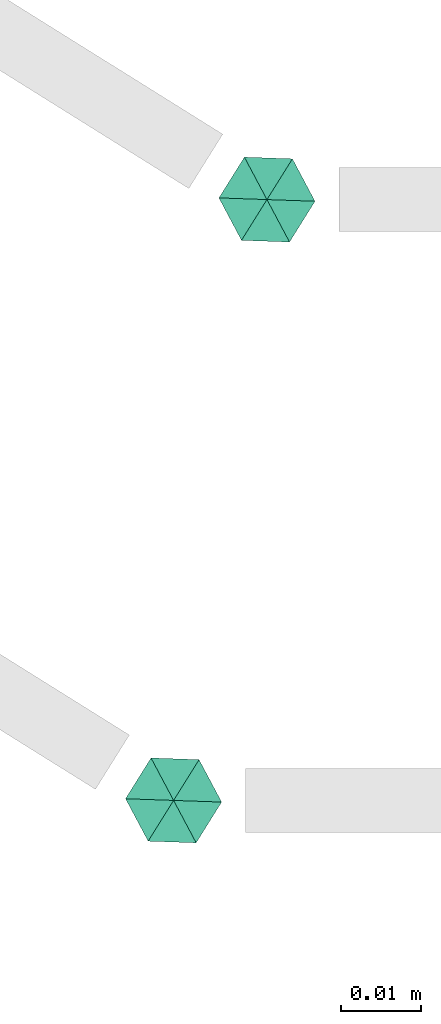
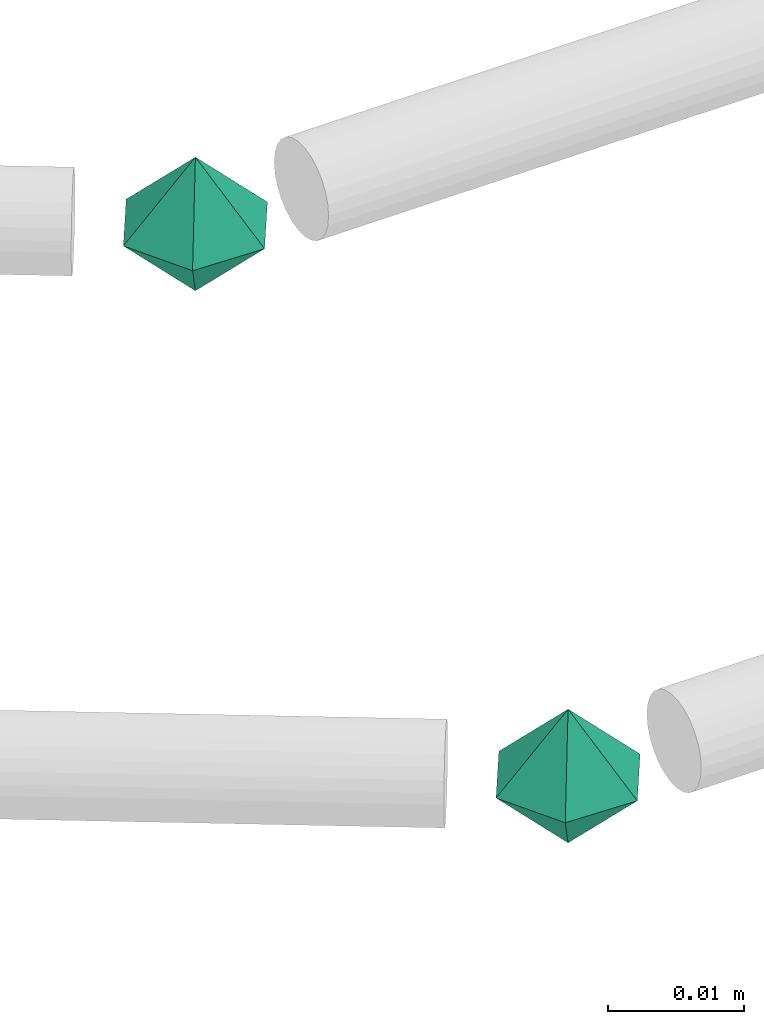
# One storey, part 50 of 65: 2 flow fittings.
"""IFC2X3 building model written with IfcOpenShell, lengths in millimetres."""

from ifc_helpers import new_model, entity, si_unit, converted_unit, derived_unit, direction, frame, origin, place, context, subcontext, project, spatial, faceted_brep, source, transform, mapped, material, material_list, type_object, type_shapes, element, save


model = new_model("IFC2X3")

# Units and contexts
model_context = context("Model", 3, precision=0.01, world=origin(), true_north=direction((6.12303176911189e-17, 1.0)))
body_context = subcontext(model_context, "Body", "Model", "MODEL_VIEW")
ifc_project = project(units=[si_unit("LENGTHUNIT", "METRE", prefix="MILLI"), si_unit("AREAUNIT", "SQUARE_METRE"), si_unit("VOLUMEUNIT", "CUBIC_METRE"), converted_unit("PLANEANGLEUNIT", "DEGREE", entity("IfcRatioMeasure", 0.0174532925199433), si_unit("PLANEANGLEUNIT", "RADIAN"), dimensions=[0, 0, 0, 0, 0, 0, 0]), si_unit("MASSUNIT", "GRAM", prefix="KILO"), derived_unit("MASSDENSITYUNIT", [(si_unit("MASSUNIT", "GRAM", prefix="KILO"), 1), (si_unit("LENGTHUNIT", "METRE"), -3)]), derived_unit("MOMENTOFINERTIAUNIT", [(si_unit("LENGTHUNIT", "METRE"), 4)]), si_unit("TIMEUNIT", "SECOND"), si_unit("FREQUENCYUNIT", "HERTZ"), si_unit("THERMODYNAMICTEMPERATUREUNIT", "DEGREE_CELSIUS"), derived_unit("THERMALTRANSMITTANCEUNIT", [(si_unit("MASSUNIT", "GRAM", prefix="KILO"), 1), (si_unit("THERMODYNAMICTEMPERATUREUNIT", "KELVIN"), -1), (si_unit("TIMEUNIT", "SECOND"), -3)]), derived_unit("VOLUMETRICFLOWRATEUNIT", [(si_unit("LENGTHUNIT", "METRE"), 3), (si_unit("TIMEUNIT", "SECOND"), -1)]), derived_unit("MASSFLOWRATEUNIT", [(si_unit("MASSUNIT", "GRAM", prefix="KILO"), 1), (si_unit("TIMEUNIT", "SECOND"), -1)]), derived_unit("ROTATIONALFREQUENCYUNIT", [(si_unit("TIMEUNIT", "SECOND"), -1)]), si_unit("ELECTRICCURRENTUNIT", "AMPERE"), si_unit("ELECTRICVOLTAGEUNIT", "VOLT"), si_unit("POWERUNIT", "WATT"), si_unit("FORCEUNIT", "NEWTON", prefix="KILO"), si_unit("ILLUMINANCEUNIT", "LUX"), si_unit("LUMINOUSFLUXUNIT", "LUMEN"), si_unit("LUMINOUSINTENSITYUNIT", "CANDELA"), derived_unit("USERDEFINED", [(si_unit("MASSUNIT", "GRAM", prefix="KILO"), -1), (si_unit("LENGTHUNIT", "METRE"), -2), (si_unit("TIMEUNIT", "SECOND"), 3), (si_unit("LUMINOUSFLUXUNIT", "LUMEN"), 1)]), derived_unit("LINEARVELOCITYUNIT", [(si_unit("LENGTHUNIT", "METRE"), 1), (si_unit("TIMEUNIT", "SECOND"), -1)]), si_unit("PRESSUREUNIT", "PASCAL"), derived_unit("USERDEFINED", [(si_unit("LENGTHUNIT", "METRE"), -2), (si_unit("MASSUNIT", "GRAM", prefix="KILO"), 1), (si_unit("TIMEUNIT", "SECOND"), -2)]), derived_unit("LINEARFORCEUNIT", [(si_unit("MASSUNIT", "GRAM", prefix="KILO"), 1), (si_unit("LENGTHUNIT", "METRE"), 1), (si_unit("TIMEUNIT", "SECOND"), -2), (si_unit("LENGTHUNIT", "METRE"), -1)]), derived_unit("PLANARFORCEUNIT", [(si_unit("MASSUNIT", "GRAM", prefix="KILO"), 1), (si_unit("LENGTHUNIT", "METRE"), 1), (si_unit("TIMEUNIT", "SECOND"), -2), (si_unit("LENGTHUNIT", "METRE"), -2)])], contexts=[model_context])

# Site, building, storey
site_placement = place(None, frame((0.0, -0.00077364408347762, 0.0)))
site = spatial("IfcSite", under=ifc_project, at=site_placement, CompositionType="ELEMENT")
building_placement = place(site_placement, origin())
building = spatial("IfcBuilding", under=site, at=building_placement, CompositionType="ELEMENT")
storey_placement = place(building_placement, frame((0.0, 0.0, 19800.0)))
storey = spatial("IfcBuildingStorey", under=building, at=storey_placement, CompositionType="ELEMENT", Elevation=19800.0)

# Flow fittings
ifc_material_1 = material()
ifc_material_2 = material()
ifc_material_list = material_list([ifc_material_2, ifc_material_1])
pipe_fitting_type = type_object("IfcPipeFittingType", PredefinedType="NOTDEFINED", material=ifc_material_list)
shared_shape = source(origin(), body_context, "Body", "Brep", [
    faceted_brep([(5.19615242271291, 3.0, 0.0), (1.81736279215797e-07, 1.95255435220254e-07, -6.0), (0.0, 6.0, 0.0), (5.19615242271289, -3.0, 0.0), (0.0, -6.0, 0.0), (-5.19615242270038, 3.0, 0.0), (-5.19615242270037, -3.0, 0.0), (-7.73803144365858e-08, 6.63990943561288e-08, 6.0)], [[[0, 1, 2]], [[1, 0, 3]], [[1, 3, 4]], [[5, 1, 6]], [[1, 4, 6]], [[2, 1, 5]], [[5, 7, 2]], [[7, 5, 6]], [[7, 6, 4]], [[0, 7, 3]], [[7, 4, 3]], [[2, 7, 0]]]),
])
type_shapes(pipe_fitting_type, [shared_shape])
for number, where, z_axis, x_axis in (
    (1, (20462.5175600798, 425.0, 3050.0), (0.0, 0.0, 1.0), (0.848048096156425, -0.529919264233207, 0.0)),
    (2, (20474.171349455, 500.0, 3050.0), (0.0, 3.40700104726064e-08, 1.0), (0.848048096156424, -0.529919264233207, 1.80543548820613e-08)),
):
    element("IfcFlowFitting", number, at=place(storey_placement, frame(where, z_axis=z_axis, x_axis=x_axis)), inside=storey, type_object=pipe_fitting_type, material=ifc_material_1, context=body_context, shape_type="MappedRepresentation", body=[
        mapped(shared_shape, transform((0.0, 0.0, 0.0), scale=1.0)),
    ])

save(model, "model.ifc")
